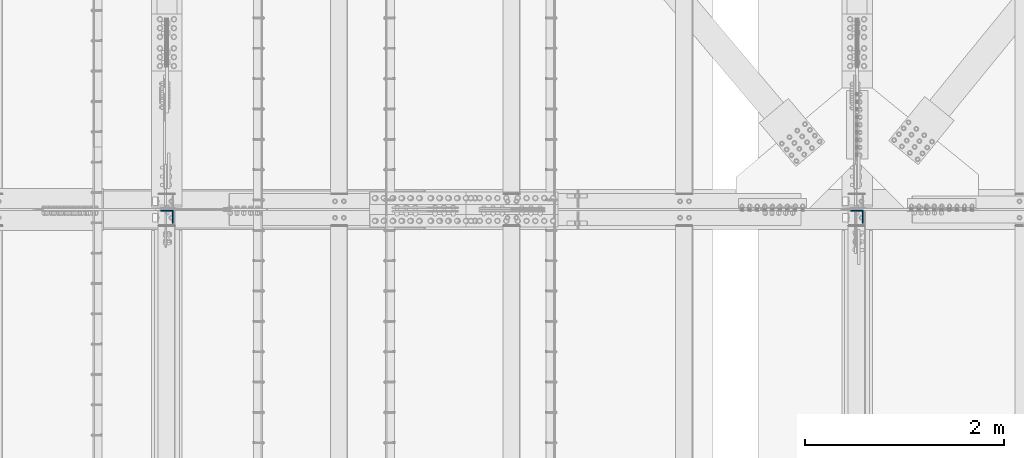
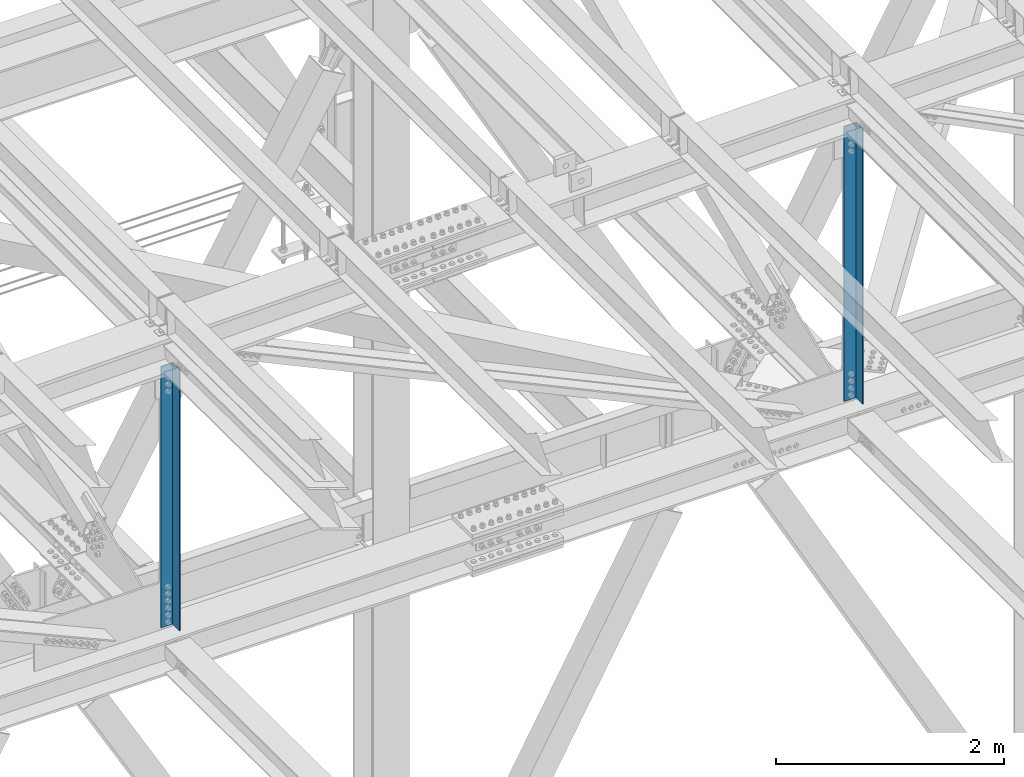
# One storey, part 1377 of 3843: 2 columns, 2 elements without a shape of their own.
"""IFC2X3 building model written with IfcOpenShell, lengths in millimetres."""

from ifc_helpers import new_model, si_unit, frame, origin_with_axes, place, context, subcontext, project, spatial, faceted_brep, material, type_object, element, aggregate, save


model = new_model("IFC2X3")

# Units and contexts
model_context = context("Model", 3, precision=1e-05, world=origin_with_axes())
body_context = subcontext(model_context, "Body", "Model", "MODEL_VIEW")
ifc_project = project(units=[si_unit("LENGTHUNIT", "METRE", prefix="MILLI"), si_unit("AREAUNIT", "SQUARE_METRE"), si_unit("VOLUMEUNIT", "CUBIC_METRE"), si_unit("MASSUNIT", "GRAM", prefix="KILO"), si_unit("TIMEUNIT", "SECOND"), si_unit("PLANEANGLEUNIT", "RADIAN"), si_unit("SOLIDANGLEUNIT", "STERADIAN"), si_unit("THERMODYNAMICTEMPERATUREUNIT", "DEGREE_CELSIUS"), si_unit("LUMINOUSINTENSITYUNIT", "LUMEN")], contexts=[model_context])

# Site, building, storey
site_placement = place(None, origin_with_axes())
site = spatial("IfcSite", under=ifc_project, at=site_placement, CompositionType="ELEMENT")
building_placement = place(site_placement, origin_with_axes())
building = spatial("IfcBuilding", under=site, at=building_placement, Name="Undefined", CompositionType="ELEMENT")
storey_placement = place(building_placement, origin_with_axes())
storey = spatial("IfcBuildingStorey", under=building, at=storey_placement, Name="Undefined", CompositionType="ELEMENT", Elevation=0.0)

# Assembly, column
assembly_1_placement = place(storey_placement, origin_with_axes())
assembly_1 = element("IfcElementAssembly", 1, at=assembly_1_placement, inside=storey, Name="ANGLE", AssemblyPlace="NOTDEFINED", PredefinedType="RIGID_FRAME")
ifc_material = material(Name="STEEL/A572-50")
column_type = type_object("IfcColumnType", Name="L5X5X3/8", PredefinedType="NOTDEFINED")
column_1_placement = place(assembly_1_placement, frame((55930.8, 83912.075, 42255.8947888559), z_axis=(-1.0, 0.0, 0.0), x_axis=(0.0, 0.0, 1.0)))
column_1 = element("IfcColumn", 2, at=column_1_placement, type_object=column_type, material=ifc_material, Name="ANGLE", ObjectType="L5X5X3/8", context=body_context, shape_type="Brep", body=[
    faceted_brep([(208.795424368807, 63.5, -63.5), (208.795424368807, 63.5, 63.5), (3161.10769106618, 63.5, 63.5), (3161.10769106618, 63.5, -63.5), (208.795424368807, 53.9750000000058, 63.5), (3161.10769106618, 53.9749999999985, 63.5), (208.795424368807, 53.9750000000058, -53.9749999999985), (3161.10769106618, 53.9749999999985, -53.9749999999985), (208.795424368807, -63.5, -53.9749999999985), (3161.10769106618, -63.5, -53.9749999999985), (208.795424368807, -63.5, -63.5), (3161.10769106618, -63.5, -63.5)], [[[0, 1, 2, 3]], [[1, 4, 5, 2]], [[4, 6, 7, 5]], [[6, 8, 9, 7]], [[8, 10, 11, 9]], [[10, 0, 3, 11]], [[5, 7, 9, 11, 3, 2]], [[10, 8, 6, 4, 1, 0]]]),
])
aggregate(assembly_1, [column_1])

assembly_2_placement = place(storey_placement, origin_with_axes())
assembly_2 = element("IfcElementAssembly", 3, at=assembly_2_placement, inside=storey, Name="ANGLE", AssemblyPlace="NOTDEFINED", PredefinedType="RIGID_FRAME")
column_2_placement = place(assembly_2_placement, frame((48996.6, 83912.075, 42252.5468526912), z_axis=(-1.0, 0.0, 0.0), x_axis=(0.0, 0.0, 1.0)))
column_2 = element("IfcColumn", 4, at=column_2_placement, type_object=column_type, material=ifc_material, Name="ANGLE", ObjectType="L5X5X3/8", context=body_context, shape_type="Brep", body=[
    faceted_brep([(209.235463041936, 63.5, -63.5), (209.235463041936, 63.5, 63.5), (3014.76121823154, 63.5, 63.5), (3014.76121823154, 63.5, -63.5), (209.235463041936, 53.9749999999985, 63.5), (3014.76121823154, 53.9750000000058, 63.5), (209.235463041936, 53.9749999999985, -53.9749999999985), (3014.76121823154, 53.9750000000058, -53.9749999999985), (209.235463041936, -63.5, -53.9749999999985), (3014.76121823154, -63.5, -53.9749999999985), (209.235463041936, -63.5, -63.5), (3014.76121823154, -63.5, -63.5)], [[[0, 1, 2, 3]], [[1, 4, 5, 2]], [[4, 6, 7, 5]], [[6, 8, 9, 7]], [[8, 10, 11, 9]], [[10, 0, 3, 11]], [[5, 7, 9, 11, 3, 2]], [[10, 8, 6, 4, 1, 0]]]),
])
aggregate(assembly_2, [column_2])

save(model, "model.ifc")
